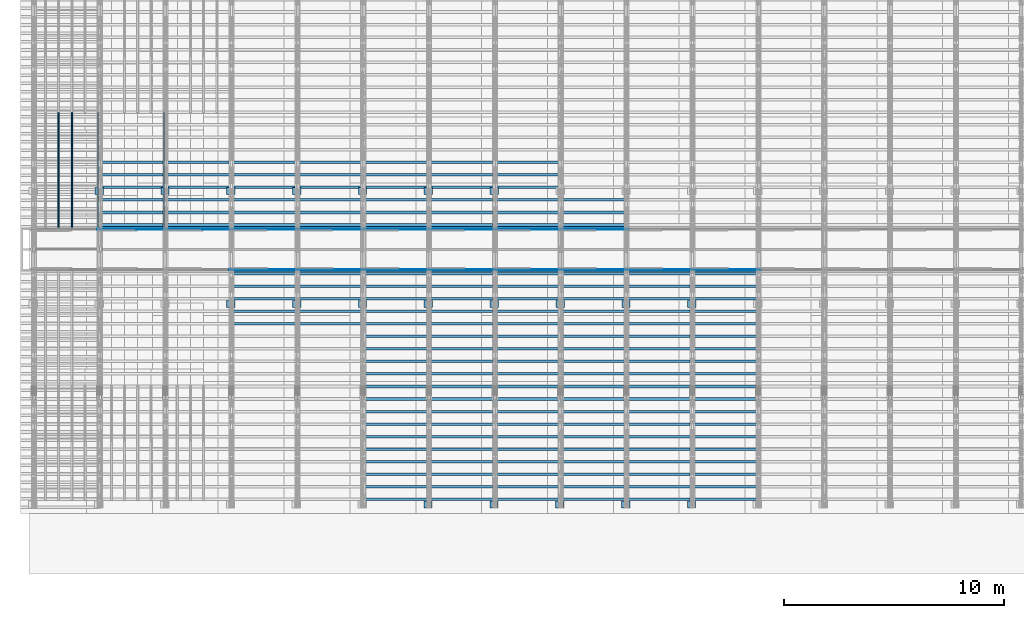
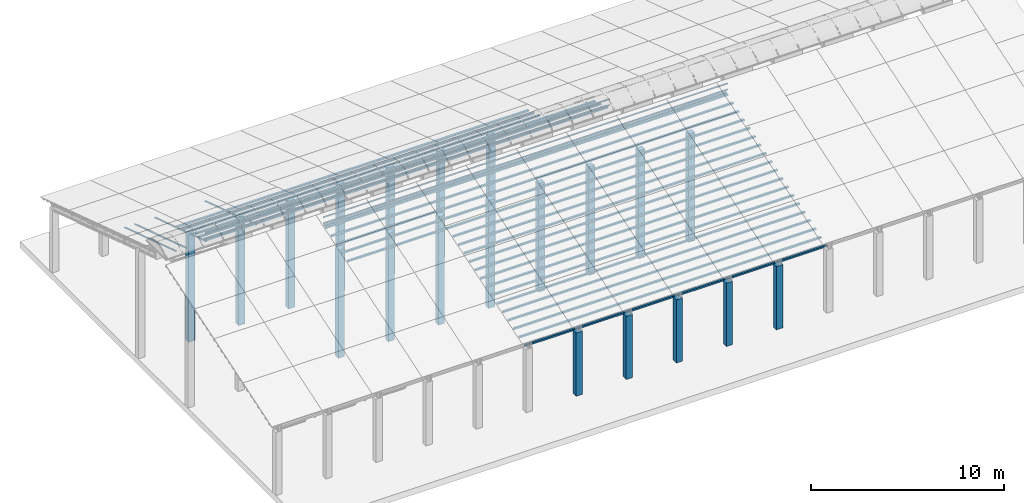
# One storey, part 2 of 385: 241 columns.
"""IFC2X3 building model written with IfcOpenShell, lengths in millimetres."""

from ifc_helpers import new_model, entity, si_unit, converted_unit, derived_unit, direction, frame, frame_2d, origin, origin_2d_with_axis, place, context, subcontext, project, spatial, rectangle, extrude, boolean, source, transform, mapped, material, type_object, type_shapes, element, save


model = new_model("IFC2X3")

# Units and contexts
model_context = context("Model", 3, precision=0.01, world=origin(), true_north=direction((6.12303176911189e-17, 1.0)))
body_context = subcontext(model_context, "Body", "Model", "MODEL_VIEW")
ifc_project = project(units=[si_unit("LENGTHUNIT", "METRE", prefix="MILLI"), si_unit("AREAUNIT", "SQUARE_METRE"), si_unit("VOLUMEUNIT", "CUBIC_METRE"), converted_unit("PLANEANGLEUNIT", "DEGREE", entity("IfcRatioMeasure", 0.0174532925199433), si_unit("PLANEANGLEUNIT", "RADIAN"), dimensions=[0, 0, 0, 0, 0, 0, 0]), si_unit("MASSUNIT", "GRAM", prefix="KILO"), derived_unit("MASSDENSITYUNIT", [(si_unit("MASSUNIT", "GRAM", prefix="KILO"), 1), (si_unit("LENGTHUNIT", "METRE"), -3)]), si_unit("TIMEUNIT", "SECOND"), si_unit("FREQUENCYUNIT", "HERTZ"), si_unit("THERMODYNAMICTEMPERATUREUNIT", "DEGREE_CELSIUS"), derived_unit("THERMALTRANSMITTANCEUNIT", [(si_unit("MASSUNIT", "GRAM", prefix="KILO"), 1), (si_unit("THERMODYNAMICTEMPERATUREUNIT", "KELVIN"), -1), (si_unit("TIMEUNIT", "SECOND"), -3)]), derived_unit("VOLUMETRICFLOWRATEUNIT", [(si_unit("LENGTHUNIT", "METRE"), 3), (si_unit("TIMEUNIT", "SECOND"), -1)]), si_unit("ELECTRICCURRENTUNIT", "AMPERE"), si_unit("ELECTRICVOLTAGEUNIT", "VOLT"), si_unit("POWERUNIT", "WATT"), si_unit("FORCEUNIT", "NEWTON", prefix="KILO"), si_unit("ILLUMINANCEUNIT", "LUX"), si_unit("LUMINOUSFLUXUNIT", "LUMEN"), si_unit("LUMINOUSINTENSITYUNIT", "CANDELA"), derived_unit("USERDEFINED", [(si_unit("MASSUNIT", "GRAM", prefix="KILO"), -1), (si_unit("LENGTHUNIT", "METRE"), -2), (si_unit("TIMEUNIT", "SECOND"), 3), (si_unit("LUMINOUSFLUXUNIT", "LUMEN"), 1)]), derived_unit("LINEARVELOCITYUNIT", [(si_unit("LENGTHUNIT", "METRE"), 1), (si_unit("TIMEUNIT", "SECOND"), -1)]), si_unit("PRESSUREUNIT", "PASCAL"), derived_unit("USERDEFINED", [(si_unit("LENGTHUNIT", "METRE"), -2), (si_unit("MASSUNIT", "GRAM", prefix="KILO"), 1), (si_unit("TIMEUNIT", "SECOND"), -2)])], contexts=[model_context])

# Site, building, storey
site_placement = place(None, origin())
site = spatial("IfcSite", under=ifc_project, at=site_placement, CompositionType="ELEMENT")
building_placement = place(site_placement, origin())
building = spatial("IfcBuilding", under=site, at=building_placement, CompositionType="ELEMENT")
storey_placement = place(building_placement, origin())
storey = spatial("IfcBuildingStorey", under=building, at=storey_placement, Name="Default", CompositionType="ELEMENT", Elevation=0.0)

# Columns
ifc_material_1 = material()
column_type_1 = type_object("IfcColumnType", Name="200x200", PredefinedType="COLUMN")
shared_shape_1 = source(origin(), body_context, "Body", "SweptSolid", [
    extrude(rectangle(XDim=379.999999999997, YDim=320.000000000004, at=origin_2d_with_axis()), frame((160.0, 300.0, -4000.0), z_axis=(0.0, 0.0, 1.0), x_axis=(0.0, -1.0, 0.0)), (0.0, 0.0, 1.0), 4000.0),
])
type_shapes(column_type_1, [shared_shape_1])
for number, where, z_axis, x_axis, name in (
    (1, (18535.0, 2940.0, 0.0), (0.0, 0.0, 1.0), (0.0, 1.0, 0.0), "V:200x200"),
    (2, (21535.0, 2940.0, 0.0), (0.0, 0.0, 1.0), (0.0, 1.0, 0.0), "V:200x200"),
    (3, (24535.0, 2940.0, 0.0), (0.0, 0.0, 1.0), (0.0, 1.0, 0.0), "V:200x200"),
    (4, (27535.0, 2940.0, 0.0), (0.0, 0.0, 1.0), (0.0, 1.0, 0.0), "V:200x200"),
    (5, (30535.0, 2940.0, 0.0), (0.0, 0.0, 1.0), (0.0, 1.0, 0.0), "V:200x200"),
):
    element("IfcColumn", number, at=place(storey_placement, frame(where, z_axis=z_axis, x_axis=x_axis)), inside=storey, type_object=column_type_1, material=ifc_material_1, Name=name, ObjectType="V:200x200", context=body_context, shape_type="MappedRepresentation", body=[
        mapped(shared_shape_1, transform((0.0, 0.0, 0.0), scale=1.0)),
    ])
column_type_2 = type_object("IfcColumnType", Name="200x200", PredefinedType="COLUMN")
shared_shape_2 = source(origin(), body_context, "Body", "SweptSolid", [
    extrude(rectangle(XDim=379.999999999997, YDim=320.000000000004, at=origin_2d_with_axis()), frame((160.0, 300.0, -4000.0), z_axis=(0.0, 0.0, 1.0), x_axis=(0.0, -1.0, 0.0)), (0.0, 0.0, 1.0), 6794.3),
])
type_shapes(column_type_2, [shared_shape_2])
for number, where, z_axis, x_axis, name in (
    (6, (3550.0, 17220.0, 0.0), (0.0, 0.0, 1.0), (0.0, 1.0, 0.0), "V:200x200"),
    (7, (6550.0, 17220.0, 0.0), (0.0, 0.0, 1.0), (0.0, 1.0, 0.0), "V:200x200"),
    (8, (9550.0, 17220.0, 0.0), (0.0, 0.0, 1.0), (0.0, 1.0, 0.0), "V:200x200"),
    (9, (12550.0, 17220.0, 0.0), (0.0, 0.0, 1.0), (0.0, 1.0, 0.0), "V:200x200"),
    (10, (15550.0, 17220.0, 0.0), (0.0, 0.0, 1.0), (0.0, 1.0, 0.0), "V:200x200"),
    (11, (18550.0, 17220.0, 0.0), (0.0, 0.0, 1.0), (0.0, 1.0, 0.0), "V:200x200"),
    (12, (21550.0, 17220.0, 0.0), (0.0, 0.0, 1.0), (0.0, 1.0, 0.0), "V:200x200"),
):
    element("IfcColumn", number, at=place(storey_placement, frame(where, z_axis=z_axis, x_axis=x_axis)), inside=storey, type_object=column_type_2, material=ifc_material_1, Name=name, ObjectType="V:200x200", context=body_context, shape_type="MappedRepresentation", body=[
        mapped(shared_shape_2, transform((0.0, 0.0, 0.0), scale=1.0)),
    ])
column_type_3 = type_object("IfcColumnType", Name="200x200", PredefinedType="COLUMN")
shared_shape_3 = source(origin(), body_context, "Body", "SweptSolid", [
    extrude(rectangle(XDim=379.999999999997, YDim=320.000000000004, at=origin_2d_with_axis()), frame((160.0, 300.0, -4000.0), z_axis=(0.0, 0.0, 1.0), x_axis=(0.0, -1.0, 0.0)), (0.0, 0.0, 1.0), 6849.5),
])
type_shapes(column_type_3, [shared_shape_3])
for number, where, z_axis, x_axis, name in (
    (13, (9550.0, 12070.0, 0.0), (0.0, 0.0, 1.0), (0.0, 1.0, 0.0), "V:200x200"),
    (14, (12550.0, 12070.0, 0.0), (0.0, 0.0, 1.0), (0.0, 1.0, 0.0), "V:200x200"),
    (15, (15550.0, 12070.0, 0.0), (0.0, 0.0, 1.0), (0.0, 1.0, 0.0), "V:200x200"),
    (16, (18550.0, 12070.0, 0.0), (0.0, 0.0, 1.0), (0.0, 1.0, 0.0), "V:200x200"),
    (17, (21550.0, 12070.0, 0.0), (0.0, 0.0, 1.0), (0.0, 1.0, 0.0), "V:200x200"),
    (18, (24550.0, 12070.0, 0.0), (0.0, 0.0, 1.0), (0.0, 1.0, 0.0), "V:200x200"),
    (19, (27550.0, 12070.0, 0.0), (0.0, 0.0, 1.0), (0.0, 1.0, 0.0), "V:200x200"),
    (20, (30550.0, 12070.0, 0.0), (0.0, 0.0, 1.0), (0.0, 1.0, 0.0), "V:200x200"),
):
    element("IfcColumn", number, at=place(storey_placement, frame(where, z_axis=z_axis, x_axis=x_axis)), inside=storey, type_object=column_type_3, material=ifc_material_1, Name=name, ObjectType="V:200x200", context=body_context, shape_type="MappedRepresentation", body=[
        mapped(shared_shape_3, transform((0.0, 0.0, 0.0), scale=1.0)),
    ])
ifc_material_2 = material(Name="2")
column_type_4 = type_object("IfcColumnType", Name="100x70", PredefinedType="COLUMN")
shared_shape_4 = source(origin(), body_context, "Body", "CSG", [
    boolean("DIFFERENCE", extrude(rectangle(XDim=3112.0299471758, YDim=116.736841236773, at=origin_2d_with_axis()), frame((1556.0149735879, 145.11006420193, -28.6286403914128)), (0.0, 0.0, 1.0), 97.4756555803792), extrude(rectangle(XDim=70.0000000018648, YDim=100.00000000027, at=frame_2d((0.0, 3.5527136788005e-15), x_axis=(0.0, 1.0))), frame((3112.0299471758, 145.11006420193, 20.1091873987768), z_axis=(1.0, 0.0, 0.0), x_axis=(0.0, 0.951056516293611, -0.309016994379696)), (0.0, 0.0, -1.0), 3112.0299471758)),
])
type_shapes(column_type_4, [shared_shape_4])
for number, where, name in (
    (21, (3175.0, 18538.2806880791, 2372.38724037744), "H_28_35_gradi:100x70"),
    (22, (3175.0, 17967.646778302, 2557.79743700247), "H_28_35_gradi:100x70"),
    (23, (3175.0, 17397.012868525, 2743.20763362749), "H_28_35_gradi:100x70"),
    (24, (3175.0, 16826.3789587479, 2928.61783025252), "H_28_35_gradi:100x70"),
    (25, (3175.0, 16255.7450489708, 3114.02802687754), "H_28_35_gradi:100x70"),
    (26, (3175.0, 15685.1111391938, 3299.43822350257), "H_28_35_gradi:100x70"),
    (27, (3175.0, 15551.9632269124, 3342.70060271507), "H_28_35_gradi:100x70"),
    (28, (6175.0, 18538.2806880791, 2372.38724037744), "H_28_35_gradi:100x70"),
    (29, (6175.0, 17967.646778302, 2557.79743700247), "H_28_35_gradi:100x70"),
    (30, (6175.0, 17397.012868525, 2743.20763362749), "H_28_35_gradi:100x70"),
    (31, (6175.0, 16826.3789587479, 2928.61783025252), "H_28_35_gradi:100x70"),
    (32, (6175.0, 16255.7450489708, 3114.02802687754), "H_28_35_gradi:100x70"),
    (33, (6175.0, 15685.1111391937, 3299.43822350257), "H_28_35_gradi:100x70"),
    (34, (6175.0, 15551.9632269124, 3342.70060271507), "H_28_35_gradi:100x70"),
    (35, (9175.0, 18538.2806880791, 2372.38724037744), "H_28_35_gradi:100x70"),
    (36, (9175.0, 17967.646778302, 2557.79743700247), "H_28_35_gradi:100x70"),
    (37, (9175.0, 17397.012868525, 2743.20763362749), "H_28_35_gradi:100x70"),
    (38, (9175.0, 16826.3789587479, 2928.61783025252), "H_28_35_gradi:100x70"),
    (39, (9175.0, 16255.7450489708, 3114.02802687754), "H_28_35_gradi:100x70"),
    (40, (9175.0, 15685.1111391937, 3299.43822350257), "H_28_35_gradi:100x70"),
    (41, (9175.0, 15551.9632269124, 3342.70060271507), "H_28_35_gradi:100x70"),
    (42, (12175.0, 18538.2806880791, 2372.38724037744), "H_28_35_gradi:100x70"),
    (43, (12175.0, 17967.646778302, 2557.79743700247), "H_28_35_gradi:100x70"),
    (44, (12175.0, 17397.0128685249, 2743.20763362749), "H_28_35_gradi:100x70"),
    (45, (12175.0, 16826.3789587479, 2928.61783025252), "H_28_35_gradi:100x70"),
    (46, (12175.0, 16255.7450489708, 3114.02802687754), "H_28_35_gradi:100x70"),
    (47, (12175.0, 15685.1111391937, 3299.43822350257), "H_28_35_gradi:100x70"),
    (48, (12175.0, 15551.9632269124, 3342.70060271507), "H_28_35_gradi:100x70"),
    (49, (15175.0, 18538.2806880791, 2372.38724037744), "H_28_35_gradi:100x70"),
    (50, (15175.0, 17967.646778302, 2557.79743700247), "H_28_35_gradi:100x70"),
    (51, (15175.0, 17397.0128685249, 2743.20763362749), "H_28_35_gradi:100x70"),
    (52, (15175.0, 16826.3789587479, 2928.61783025252), "H_28_35_gradi:100x70"),
    (53, (15175.0, 16255.7450489708, 3114.02802687754), "H_28_35_gradi:100x70"),
    (54, (15175.0, 15685.1111391937, 3299.43822350257), "H_28_35_gradi:100x70"),
    (55, (15175.0, 15551.9632269124, 3342.70060271507), "H_28_35_gradi:100x70"),
    (56, (18175.0, 18538.2806880791, 2372.38724037744), "H_28_35_gradi:100x70"),
    (57, (18175.0, 17967.646778302, 2557.79743700247), "H_28_35_gradi:100x70"),
    (58, (18175.0, 17397.0128685249, 2743.20763362749), "H_28_35_gradi:100x70"),
    (59, (18175.0, 16826.3789587479, 2928.61783025252), "H_28_35_gradi:100x70"),
    (60, (18175.0, 16255.7450489708, 3114.02802687754), "H_28_35_gradi:100x70"),
    (61, (18175.0, 15685.1111391937, 3299.43822350257), "H_28_35_gradi:100x70"),
    (62, (18175.0, 15551.9632269124, 3342.70060271507), "H_28_35_gradi:100x70"),
    (63, (21175.0, 18538.2806880791, 2372.38724037744), "H_28_35_gradi:100x70"),
    (64, (21175.0, 17967.646778302, 2557.79743700247), "H_28_35_gradi:100x70"),
    (65, (21175.0, 17397.0128685249, 2743.20763362749), "H_28_35_gradi:100x70"),
    (66, (21175.0, 16826.3789587478, 2928.61783025252), "H_28_35_gradi:100x70"),
    (67, (21175.0, 16255.7450489708, 3114.02802687754), "H_28_35_gradi:100x70"),
    (68, (21175.0, 15685.1111391937, 3299.43822350257), "H_28_35_gradi:100x70"),
    (69, (21175.0, 15551.9632269124, 3342.70060271507), "H_28_35_gradi:100x70"),
    (70, (24175.0, 16826.3789587478, 2928.61783025252), "H_28_35_gradi:100x70"),
    (71, (24175.0, 16255.7450489708, 3114.02802687754), "H_28_35_gradi:100x70"),
    (72, (24175.0, 15685.1111391937, 3299.43822350257), "H_28_35_gradi:100x70"),
    (73, (24175.0, 15551.9632269124, 3342.70060271507), "H_28_35_gradi:100x70"),
):
    element("IfcColumn", number, at=place(storey_placement, frame(where)), inside=storey, type_object=column_type_4, material=ifc_material_2, Name=name, ObjectType="H_28_35_gradi:100x70", context=body_context, shape_type="MappedRepresentation", body=[
        mapped(shared_shape_4, transform((0.0, 0.0, 0.0), scale=1.0)),
    ])
column_type_5 = type_object("IfcColumnType", Name="45x70", PredefinedType="COLUMN")
shared_shape_5 = source(origin(), body_context, "Body", "SweptSolid", [
    extrude(rectangle(XDim=5592.10619540062, YDim=70.0, at=frame_2d((0.0, -6.82121026329696e-13), x_axis=(0.0, 1.0))), frame((2659.20451847513, -237.823014276398, 864.027924364111), z_axis=(-0.309016994374947, 0.0, 0.951056516295154), x_axis=(0.0, 1.0, 0.0)), (0.0, 0.0, 1.0), 44.9999999999777),
])
type_shapes(column_type_5, [shared_shape_5])
for number, where, z_axis, x_axis, name in (
    (74, (1647.82301427638, 20941.2050318427, 1574.77111996836), (0.0, 0.0, 1.0), (0.0, -1.0, 0.0), "H:45x70"),
    (75, (2247.82301427638, 20941.2050318427, 1574.77111996836), (0.0, 0.0, 1.0), (0.0, -1.0, 0.0), "H:45x70"),
    (76, (3447.82301427638, 20941.2050318427, 1574.77111996836), (0.0, 0.0, 1.0), (0.0, -1.0, 0.0), "H:45x70"),
    (77, (6447.82301427638, 20941.2050318426, 1574.77111996836), (0.0, 0.0, 1.0), (0.0, -1.0, 0.0), "H:45x70"),
):
    element("IfcColumn", number, at=place(storey_placement, frame(where, z_axis=z_axis, x_axis=x_axis)), inside=storey, type_object=column_type_5, material=ifc_material_2, Name=name, ObjectType="H:45x70", context=body_context, shape_type="MappedRepresentation", body=[
        mapped(shared_shape_5, transform((0.0, 0.0, 0.0), scale=1.0)),
    ])
column_type_6 = type_object("IfcColumnType", Name="100x70", PredefinedType="COLUMN")
shared_shape_6 = source(origin(), body_context, "Body", "CSG", [
    boolean("DIFFERENCE", extrude(rectangle(XDim=3112.0299471758, YDim=116.736841236773, at=origin_2d_with_axis()), frame((1556.0149735879, -145.11006420193, -28.6286403914128)), (0.0, 0.0, 1.0), 97.4756555803792), extrude(rectangle(XDim=70.0000000018648, YDim=100.00000000027, at=frame_2d((0.0, 3.5527136788005e-15), x_axis=(0.0, 1.0))), frame((0.0, -145.11006420193, 20.1091873987768), z_axis=(-1.0, 0.0, 0.0), x_axis=(0.0, -0.951056516293611, -0.309016994379696)), (0.0, 0.0, -1.0), 3112.0299471758)),
])
type_shapes(column_type_6, [shared_shape_6])
for number, where, name in (
    (78, (9175.0, 11472.3530522482, 2557.79743700247), "H_28_35_gradi:100x70"),
    (79, (9175.0, 12042.9869620253, 2743.20763362749), "H_28_35_gradi:100x70"),
    (80, (9175.0, 12613.6208718024, 2928.61783025252), "H_28_35_gradi:100x70"),
    (81, (9175.0, 13184.2547815795, 3114.02802687754), "H_28_35_gradi:100x70"),
    (82, (9175.0, 13754.8886913565, 3299.43822350257), "H_28_35_gradi:100x70"),
    (83, (9175.0, 13888.0366036378, 3342.70060271507), "H_28_35_gradi:100x70"),
    (84, (12175.0, 11472.3530522482, 2557.79743700247), "H_28_35_gradi:100x70"),
    (85, (12175.0, 12042.9869620253, 2743.20763362749), "H_28_35_gradi:100x70"),
    (86, (12175.0, 12613.6208718024, 2928.61783025252), "H_28_35_gradi:100x70"),
    (87, (12175.0, 13184.2547815794, 3114.02802687754), "H_28_35_gradi:100x70"),
    (88, (12175.0, 13754.8886913565, 3299.43822350257), "H_28_35_gradi:100x70"),
    (89, (12175.0, 13888.0366036378, 3342.70060271507), "H_28_35_gradi:100x70"),
    (90, (15175.0, 3483.47831537058, -37.9453157522206), "H_28_35_gradi:100x70"),
    (91, (15175.0, 4054.11222514633, 147.464880876897), "H_28_35_gradi:100x70"),
    (92, (15175.0, 4624.74613492331, 332.8750775022), "H_28_35_gradi:100x70"),
    (93, (15175.0, 5195.38004470041, 518.285274127168), "H_28_35_gradi:100x70"),
    (94, (15175.0, 5766.01395447747, 703.695470752224), "H_28_35_gradi:100x70"),
    (95, (15175.0, 6336.64786425454, 889.105667377245), "H_28_35_gradi:100x70"),
    (96, (15175.0, 6907.28177403162, 1074.51586400227), "H_28_35_gradi:100x70"),
    (97, (15175.0, 7477.91568380869, 1259.92606062729), "H_28_35_gradi:100x70"),
    (98, (15175.0, 8048.54959358577, 1445.33625725232), "H_28_35_gradi:100x70"),
    (99, (15175.0, 8619.18350336284, 1630.74645387734), "H_28_35_gradi:100x70"),
    (100, (15175.0, 9189.81741313992, 1816.15665050237), "H_28_35_gradi:100x70"),
    (101, (15175.0, 9760.451322917, 2001.56684712739), "H_28_35_gradi:100x70"),
    (102, (15175.0, 10331.0852326941, 2186.97704375242), "H_28_35_gradi:100x70"),
    (103, (15175.0, 10901.7191424711, 2372.38724037744), "H_28_35_gradi:100x70"),
    (104, (15175.0, 11472.3530522482, 2557.79743700247), "H_28_35_gradi:100x70"),
    (105, (15175.0, 12042.9869620253, 2743.20763362749), "H_28_35_gradi:100x70"),
    (106, (15175.0, 12613.6208718024, 2928.61783025252), "H_28_35_gradi:100x70"),
    (107, (15175.0, 13184.2547815794, 3114.02802687754), "H_28_35_gradi:100x70"),
    (108, (15175.0, 13754.8886913565, 3299.43822350257), "H_28_35_gradi:100x70"),
    (109, (15175.0, 13888.0366036378, 3342.70060271507), "H_28_35_gradi:100x70"),
    (110, (18175.0, 3483.47831537057, -37.9453157522206), "H_28_35_gradi:100x70"),
    (111, (18175.0, 4054.11222514632, 147.464880876897), "H_28_35_gradi:100x70"),
    (112, (18175.0, 4624.7461349233, 332.8750775022), "H_28_35_gradi:100x70"),
    (113, (18175.0, 5195.3800447004, 518.285274127168), "H_28_35_gradi:100x70"),
    (114, (18175.0, 5766.01395447746, 703.695470752224), "H_28_35_gradi:100x70"),
    (115, (18175.0, 6336.64786425453, 889.105667377245), "H_28_35_gradi:100x70"),
    (116, (18175.0, 6907.28177403161, 1074.51586400227), "H_28_35_gradi:100x70"),
    (117, (18175.0, 7477.91568380868, 1259.92606062729), "H_28_35_gradi:100x70"),
    (118, (18175.0, 8048.54959358576, 1445.33625725232), "H_28_35_gradi:100x70"),
    (119, (18175.0, 8619.18350336283, 1630.74645387734), "H_28_35_gradi:100x70"),
    (120, (18175.0, 9189.81741313991, 1816.15665050237), "H_28_35_gradi:100x70"),
    (121, (18175.0, 9760.45132291699, 2001.56684712739), "H_28_35_gradi:100x70"),
    (122, (18175.0, 10331.0852326941, 2186.97704375242), "H_28_35_gradi:100x70"),
    (123, (18175.0, 10901.7191424711, 2372.38724037744), "H_28_35_gradi:100x70"),
    (124, (18175.0, 11472.3530522482, 2557.79743700247), "H_28_35_gradi:100x70"),
    (125, (18175.0, 12042.9869620253, 2743.20763362749), "H_28_35_gradi:100x70"),
    (126, (18175.0, 12613.6208718024, 2928.61783025252), "H_28_35_gradi:100x70"),
    (127, (18175.0, 13184.2547815794, 3114.02802687754), "H_28_35_gradi:100x70"),
    (128, (18175.0, 13754.8886913565, 3299.43822350257), "H_28_35_gradi:100x70"),
    (129, (18175.0, 13888.0366036378, 3342.70060271507), "H_28_35_gradi:100x70"),
    (130, (21175.0, 3483.47831537056, -37.9453157522206), "H_28_35_gradi:100x70"),
    (131, (21175.0, 4054.11222514631, 147.464880876897), "H_28_35_gradi:100x70"),
    (132, (21175.0, 4624.74613492329, 332.8750775022), "H_28_35_gradi:100x70"),
    (133, (21175.0, 5195.38004470039, 518.285274127168), "H_28_35_gradi:100x70"),
    (134, (21175.0, 5766.01395447745, 703.695470752224), "H_28_35_gradi:100x70"),
    (135, (21175.0, 6336.64786425452, 889.105667377245), "H_28_35_gradi:100x70"),
    (136, (21175.0, 6907.2817740316, 1074.51586400227), "H_28_35_gradi:100x70"),
    (137, (21175.0, 7477.91568380867, 1259.92606062729), "H_28_35_gradi:100x70"),
    (138, (21175.0, 8048.54959358575, 1445.33625725232), "H_28_35_gradi:100x70"),
    (139, (21175.0, 8619.18350336282, 1630.74645387734), "H_28_35_gradi:100x70"),
    (140, (21175.0, 9189.8174131399, 1816.15665050237), "H_28_35_gradi:100x70"),
    (141, (21175.0, 9760.45132291698, 2001.56684712739), "H_28_35_gradi:100x70"),
    (142, (21175.0, 10331.085232694, 2186.97704375242), "H_28_35_gradi:100x70"),
    (143, (21175.0, 10901.7191424711, 2372.38724037744), "H_28_35_gradi:100x70"),
    (144, (21175.0, 11472.3530522482, 2557.79743700247), "H_28_35_gradi:100x70"),
    (145, (21175.0, 12042.9869620253, 2743.20763362749), "H_28_35_gradi:100x70"),
    (146, (21175.0, 12613.6208718023, 2928.61783025252), "H_28_35_gradi:100x70"),
    (147, (21175.0, 13184.2547815794, 3114.02802687754), "H_28_35_gradi:100x70"),
    (148, (21175.0, 13754.8886913565, 3299.43822350257), "H_28_35_gradi:100x70"),
    (149, (21175.0, 13888.0366036378, 3342.70060271507), "H_28_35_gradi:100x70"),
    (150, (24175.0, 3483.47831537055, -37.9453157522206), "H_28_35_gradi:100x70"),
    (151, (24175.0, 4054.1122251463, 147.464880876897), "H_28_35_gradi:100x70"),
    (152, (24175.0, 4624.74613492328, 332.8750775022), "H_28_35_gradi:100x70"),
    (153, (24175.0, 5195.38004470038, 518.285274127168), "H_28_35_gradi:100x70"),
    (154, (24175.0, 5766.01395447744, 703.695470752224), "H_28_35_gradi:100x70"),
    (155, (24175.0, 6336.64786425451, 889.105667377245), "H_28_35_gradi:100x70"),
    (156, (24175.0, 6907.28177403159, 1074.51586400227), "H_28_35_gradi:100x70"),
    (157, (24175.0, 7477.91568380866, 1259.92606062729), "H_28_35_gradi:100x70"),
    (158, (24175.0, 8048.54959358574, 1445.33625725232), "H_28_35_gradi:100x70"),
    (159, (24175.0, 8619.18350336282, 1630.74645387734), "H_28_35_gradi:100x70"),
    (160, (24175.0, 9189.81741313989, 1816.15665050237), "H_28_35_gradi:100x70"),
    (161, (24175.0, 9760.45132291697, 2001.56684712739), "H_28_35_gradi:100x70"),
    (162, (24175.0, 10331.085232694, 2186.97704375242), "H_28_35_gradi:100x70"),
    (163, (24175.0, 10901.7191424711, 2372.38724037744), "H_28_35_gradi:100x70"),
    (164, (24175.0, 11472.3530522482, 2557.79743700247), "H_28_35_gradi:100x70"),
    (165, (24175.0, 12042.9869620253, 2743.20763362749), "H_28_35_gradi:100x70"),
    (166, (24175.0, 12613.6208718023, 2928.61783025252), "H_28_35_gradi:100x70"),
    (167, (24175.0, 13184.2547815794, 3114.02802687754), "H_28_35_gradi:100x70"),
    (168, (24175.0, 13754.8886913565, 3299.43822350257), "H_28_35_gradi:100x70"),
    (169, (24175.0, 13888.0366036378, 3342.70060271507), "H_28_35_gradi:100x70"),
    (170, (27175.0, 3483.47831537054, -37.9453157522206), "H_28_35_gradi:100x70"),
    (171, (27175.0, 4054.11222514629, 147.464880876897), "H_28_35_gradi:100x70"),
    (172, (27175.0, 4624.74613492327, 332.8750775022), "H_28_35_gradi:100x70"),
    (173, (27175.0, 5195.38004470037, 518.285274127168), "H_28_35_gradi:100x70"),
    (174, (27175.0, 5766.01395447743, 703.695470752224), "H_28_35_gradi:100x70"),
    (175, (27175.0, 6336.6478642545, 889.105667377245), "H_28_35_gradi:100x70"),
    (176, (27175.0, 6907.28177403158, 1074.51586400227), "H_28_35_gradi:100x70"),
    (177, (27175.0, 7477.91568380865, 1259.92606062729), "H_28_35_gradi:100x70"),
    (178, (27175.0, 8048.54959358573, 1445.33625725232), "H_28_35_gradi:100x70"),
    (179, (27175.0, 8619.1835033628, 1630.74645387734), "H_28_35_gradi:100x70"),
    (180, (27175.0, 9189.81741313988, 1816.15665050237), "H_28_35_gradi:100x70"),
    (181, (27175.0, 9760.45132291696, 2001.56684712739), "H_28_35_gradi:100x70"),
    (182, (27175.0, 10331.085232694, 2186.97704375242), "H_28_35_gradi:100x70"),
    (183, (27175.0, 10901.7191424711, 2372.38724037744), "H_28_35_gradi:100x70"),
    (184, (27175.0, 11472.3530522482, 2557.79743700247), "H_28_35_gradi:100x70"),
    (185, (27175.0, 12042.9869620253, 2743.20763362749), "H_28_35_gradi:100x70"),
    (186, (27175.0, 12613.6208718023, 2928.61783025252), "H_28_35_gradi:100x70"),
    (187, (27175.0, 13184.2547815794, 3114.02802687754), "H_28_35_gradi:100x70"),
    (188, (27175.0, 13754.8886913565, 3299.43822350257), "H_28_35_gradi:100x70"),
    (189, (27175.0, 13888.0366036378, 3342.70060271507), "H_28_35_gradi:100x70"),
    (190, (30175.0, 3483.47831537053, -37.9453157522206), "H_28_35_gradi:100x70"),
    (191, (30175.0, 4054.11222514628, 147.464880876897), "H_28_35_gradi:100x70"),
    (192, (30175.0, 4624.74613492326, 332.8750775022), "H_28_35_gradi:100x70"),
    (193, (30175.0, 5195.38004470036, 518.285274127168), "H_28_35_gradi:100x70"),
    (194, (30175.0, 5766.01395447742, 703.695470752224), "H_28_35_gradi:100x70"),
    (195, (30175.0, 6336.64786425449, 889.105667377245), "H_28_35_gradi:100x70"),
    (196, (30175.0, 6907.28177403157, 1074.51586400227), "H_28_35_gradi:100x70"),
    (197, (30175.0, 7477.91568380865, 1259.92606062729), "H_28_35_gradi:100x70"),
    (198, (30175.0, 8048.54959358572, 1445.33625725232), "H_28_35_gradi:100x70"),
    (199, (30175.0, 8619.1835033628, 1630.74645387734), "H_28_35_gradi:100x70"),
    (200, (30175.0, 9189.81741313987, 1816.15665050237), "H_28_35_gradi:100x70"),
    (201, (30175.0, 9760.45132291695, 2001.56684712739), "H_28_35_gradi:100x70"),
    (202, (30175.0, 10331.085232694, 2186.97704375242), "H_28_35_gradi:100x70"),
    (203, (30175.0, 10901.7191424711, 2372.38724037744), "H_28_35_gradi:100x70"),
    (204, (30175.0, 11472.3530522482, 2557.79743700247), "H_28_35_gradi:100x70"),
    (205, (30175.0, 12042.9869620252, 2743.20763362749), "H_28_35_gradi:100x70"),
    (206, (30175.0, 12613.6208718023, 2928.61783025252), "H_28_35_gradi:100x70"),
    (207, (30175.0, 13184.2547815794, 3114.02802687754), "H_28_35_gradi:100x70"),
    (208, (30175.0, 13754.8886913565, 3299.43822350257), "H_28_35_gradi:100x70"),
    (209, (30175.0, 13888.0366036378, 3342.70060271507), "H_28_35_gradi:100x70"),
):
    element("IfcColumn", number, at=place(storey_placement, frame(where)), inside=storey, type_object=column_type_6, material=ifc_material_2, Name=name, ObjectType="H_28_35_gradi:100x70", context=body_context, shape_type="MappedRepresentation", body=[
        mapped(shared_shape_6, transform((0.0, 0.0, 0.0), scale=1.0)),
    ])
column_type_7 = type_object("IfcColumnType", Name="70x45", PredefinedType="COLUMN")
shared_shape_7 = source(origin(), body_context, "Body", "SweptSolid", [
    extrude(rectangle(XDim=45.0, YDim=3207.99969607346, at=frame_2d((-1.59872115546023e-14, 0.0), x_axis=(1.0, 0.0))), frame((1603.99984803673, 250.323014276398, 0.0), z_axis=(0.0, 0.0, 1.0), x_axis=(0.0, -1.0, 0.0)), (0.0, 0.0, 1.0), 69.9999999999776),
])
type_shapes(column_type_7, [shared_shape_7])
for number, where, z_axis, x_axis, name in (
    (210, (6382.99969607345, 15887.8230423367, 3436.65682464217), (0.0, 0.0, 1.0), (-1.0, 0.0, 0.0), "H1:70x45"),
    (211, (6382.99969607345, 15887.8230423367, 3821.65682464217), (0.0, 0.0, 1.0), (-1.0, 0.0, 0.0), "H1:70x45"),
    (212, (9382.99969607345, 15887.8230423367, 3436.65682464217), (0.0, 0.0, 1.0), (-1.0, 0.0, 0.0), "H1:70x45"),
    (213, (9382.99969607345, 15887.8230423367, 3821.65682464217), (0.0, 0.0, 1.0), (-1.0, 0.0, 0.0), "H1:70x45"),
    (214, (12382.9996960734, 15887.8230423367, 3436.65682464217), (0.0, 0.0, 1.0), (-1.0, 0.0, 0.0), "H1:70x45"),
    (215, (12382.9996960734, 15887.8230423367, 3821.65682464217), (0.0, 0.0, 1.0), (-1.0, 0.0, 0.0), "H1:70x45"),
    (216, (15382.9996960734, 15887.8230423367, 3436.65682464217), (0.0, 0.0, 1.0), (-1.0, 0.0, 0.0), "H1:70x45"),
    (217, (15382.9996960734, 15887.8230423367, 3821.65682464217), (0.0, 0.0, 1.0), (-1.0, 0.0, 0.0), "H1:70x45"),
    (218, (18382.9996960734, 15887.8230423367, 3436.65682464217), (0.0, 0.0, 1.0), (-1.0, 0.0, 0.0), "H1:70x45"),
    (219, (18382.9996960734, 15887.8230423367, 3821.65682464217), (0.0, 0.0, 1.0), (-1.0, 0.0, 0.0), "H1:70x45"),
    (220, (21382.9996960735, 15887.8230423367, 3436.65682464217), (0.0, 0.0, 1.0), (-1.0, 0.0, 0.0), "H1:70x45"),
    (221, (21382.9996960735, 15887.8230423367, 3821.65682464217), (0.0, 0.0, 1.0), (-1.0, 0.0, 0.0), "H1:70x45"),
    (222, (24382.9996960735, 15887.8230423367, 3436.65682464217), (0.0, 0.0, 1.0), (-1.0, 0.0, 0.0), "H1:70x45"),
    (223, (24382.9996960735, 15887.8230423367, 3821.65682464217), (0.0, 0.0, 1.0), (-1.0, 0.0, 0.0), "H1:70x45"),
    (224, (27382.9996960735, 15887.8230423367, 3436.65682464217), (0.0, 0.0, 1.0), (-1.0, 0.0, 0.0), "H1:70x45"),
    (225, (27382.9996960735, 15887.8230423367, 3821.65682464217), (0.0, 0.0, 1.0), (-1.0, 0.0, 0.0), "H1:70x45"),
):
    element("IfcColumn", number, at=place(storey_placement, frame(where, z_axis=z_axis, x_axis=x_axis)), inside=storey, type_object=column_type_7, material=ifc_material_2, Name=name, ObjectType="H1:70x45", context=body_context, shape_type="MappedRepresentation", body=[
        mapped(shared_shape_7, transform((0.0, 0.0, 0.0), scale=1.0)),
    ])
column_type_8 = type_object("IfcColumnType", Name="70x45", PredefinedType="COLUMN")
shared_shape_8 = source(origin(), body_context, "Body", "SweptSolid", [
    extrude(rectangle(XDim=45.0, YDim=3215.28399061289, at=frame_2d((1.59872115546023e-14, 0.0), x_axis=(1.0, 0.0))), frame((1607.64199530645, -250.323014276398, 0.0), z_axis=(0.0, 0.0, 1.0), x_axis=(0.0, -1.0, 0.0)), (0.0, 0.0, 1.0), 69.9999999999776),
])
type_shapes(column_type_8, [shared_shape_8])
for number, where, z_axis, x_axis, name in (
    (226, (12390.2839906129, 13552.1767882135, 3436.65682464217), (0.0, 0.0, 1.0), (-1.0, 0.0, 0.0), "H1:70x45"),
    (227, (12390.2839906129, 13552.1767882135, 3821.65682464217), (0.0, 0.0, 1.0), (-1.0, 0.0, 0.0), "H1:70x45"),
    (228, (15390.2839906129, 13552.1767882135, 3436.65682464217), (0.0, 0.0, 1.0), (-1.0, 0.0, 0.0), "H1:70x45"),
    (229, (15390.2839906129, 13552.1767882135, 3821.65682464217), (0.0, 0.0, 1.0), (-1.0, 0.0, 0.0), "H1:70x45"),
    (230, (18390.2839906129, 13552.1767882135, 3436.65682464217), (0.0, 0.0, 1.0), (-1.0, 0.0, 0.0), "H1:70x45"),
    (231, (18390.2839906129, 13552.1767882135, 3821.65682464217), (0.0, 0.0, 1.0), (-1.0, 0.0, 0.0), "H1:70x45"),
    (232, (21390.2839906129, 13552.1767882135, 3436.65682464217), (0.0, 0.0, 1.0), (-1.0, 0.0, 0.0), "H1:70x45"),
    (233, (21390.2839906129, 13552.1767882135, 3821.65682464217), (0.0, 0.0, 1.0), (-1.0, 0.0, 0.0), "H1:70x45"),
    (234, (24390.2839906129, 13552.1767882135, 3436.65682464217), (0.0, 0.0, 1.0), (-1.0, 0.0, 0.0), "H1:70x45"),
    (235, (24390.2839906129, 13552.1767882135, 3821.65682464217), (0.0, 0.0, 1.0), (-1.0, 0.0, 0.0), "H1:70x45"),
    (236, (27390.2839906129, 13552.1767882135, 3436.65682464217), (0.0, 0.0, 1.0), (-1.0, 0.0, 0.0), "H1:70x45"),
    (237, (27390.2839906129, 13552.1767882135, 3821.65682464217), (0.0, 0.0, 1.0), (-1.0, 0.0, 0.0), "H1:70x45"),
    (238, (30390.2839906129, 13552.1767882135, 3436.65682464217), (0.0, 0.0, 1.0), (-1.0, 0.0, 0.0), "H1:70x45"),
    (239, (30390.2839906129, 13552.1767882135, 3821.65682464217), (0.0, 0.0, 1.0), (-1.0, 0.0, 0.0), "H1:70x45"),
    (240, (33390.2839906129, 13552.1767882135, 3436.65682464217), (0.0, 0.0, 1.0), (-1.0, 0.0, 0.0), "H1:70x45"),
    (241, (33390.2839906129, 13552.1767882135, 3821.65682464217), (0.0, 0.0, 1.0), (-1.0, 0.0, 0.0), "H1:70x45"),
):
    element("IfcColumn", number, at=place(storey_placement, frame(where, z_axis=z_axis, x_axis=x_axis)), inside=storey, type_object=column_type_8, material=ifc_material_2, Name=name, ObjectType="H1:70x45", context=body_context, shape_type="MappedRepresentation", body=[
        mapped(shared_shape_8, transform((0.0, 0.0, 0.0), scale=1.0)),
    ])

save(model, "model.ifc")
